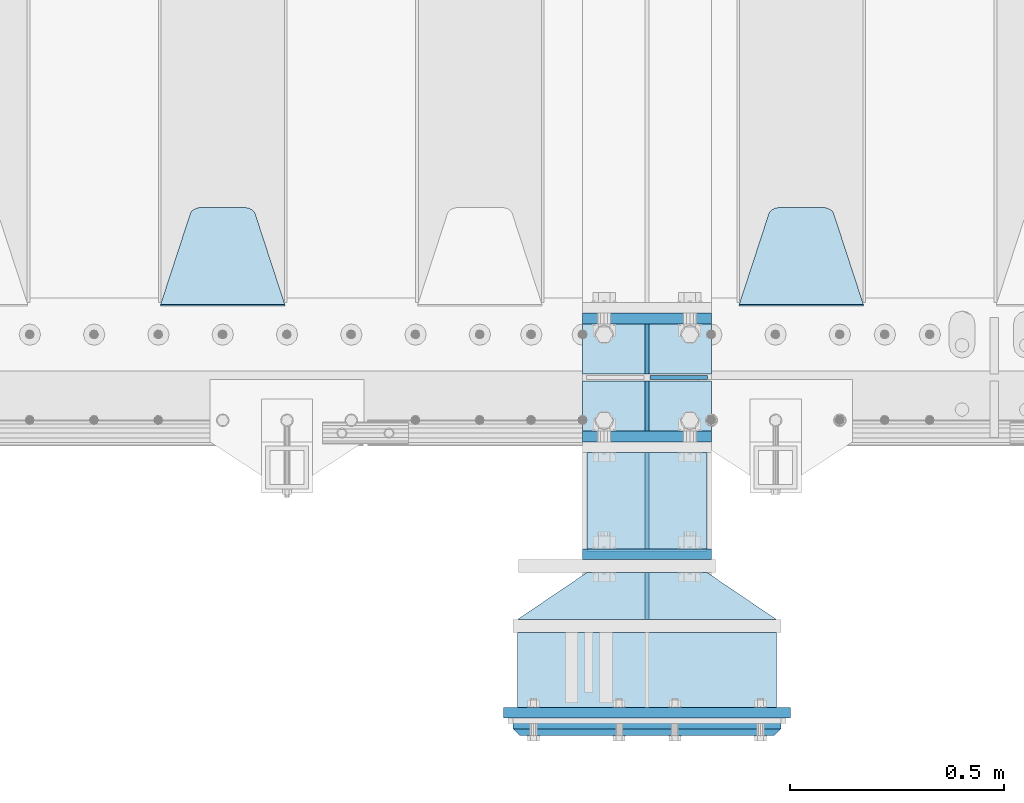
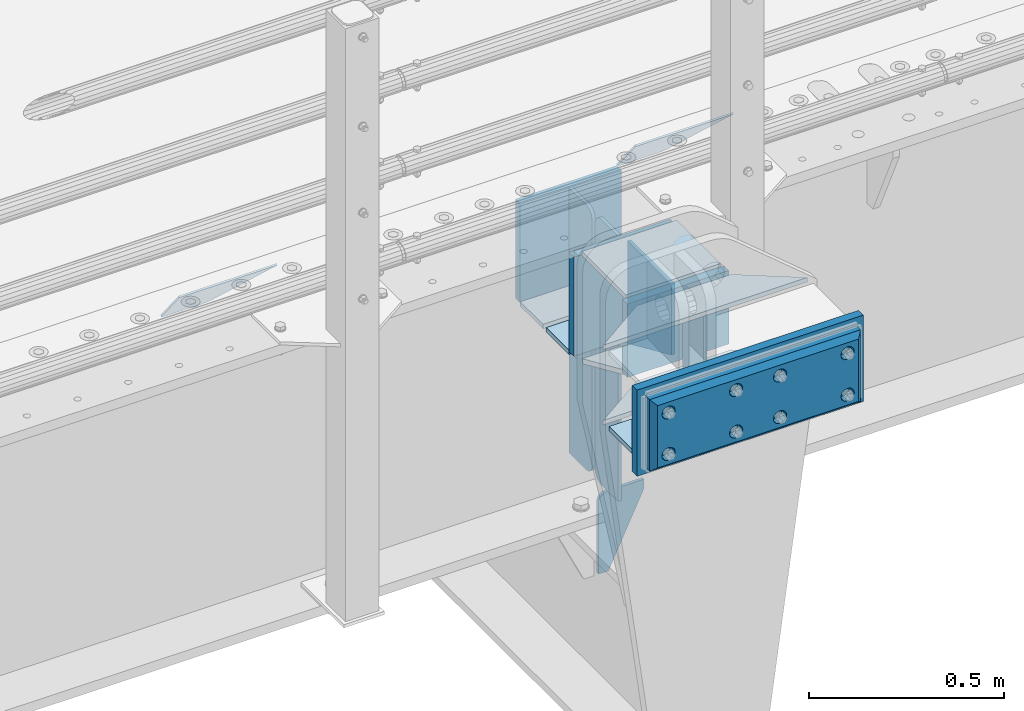
# One storey, part 166 of 193: 21 plates.
"""IFC2X3 building model written with IfcOpenShell, lengths in millimetres."""

from ifc_helpers import new_model, si_unit, frame, origin_with_axes, place, context, subcontext, project, spatial, faceted_brep, material, type_object, element, save


model = new_model("IFC2X3")

# Units and contexts
model_context = context("Model", 3, precision=1e-05, world=origin_with_axes())
body_context = subcontext(model_context, "Body", "Model", "MODEL_VIEW")
ifc_project = project(units=[si_unit("LENGTHUNIT", "METRE", prefix="MILLI"), si_unit("AREAUNIT", "SQUARE_METRE"), si_unit("VOLUMEUNIT", "CUBIC_METRE"), si_unit("MASSUNIT", "GRAM", prefix="KILO"), si_unit("TIMEUNIT", "SECOND"), si_unit("PLANEANGLEUNIT", "RADIAN"), si_unit("SOLIDANGLEUNIT", "STERADIAN"), si_unit("THERMODYNAMICTEMPERATUREUNIT", "DEGREE_CELSIUS"), si_unit("LUMINOUSINTENSITYUNIT", "LUMEN")], contexts=[model_context])

# Site, building, storey
site_placement = place(None, origin_with_axes())
site = spatial("IfcSite", under=ifc_project, at=site_placement, CompositionType="ELEMENT")
building_placement = place(site_placement, origin_with_axes())
building = spatial("IfcBuilding", under=site, at=building_placement, Name="Standard", CompositionType="ELEMENT")
storey_placement = place(building_placement, origin_with_axes())
storey = spatial("IfcBuildingStorey", under=building, at=storey_placement, Name="Undefined", CompositionType="ELEMENT", Elevation=0.0)

# Plates
ifc_material_1 = material(Name="STEEL/S355N")
plate_type_1 = type_object("IfcPlateType", PredefinedType="NOTDEFINED")
plate_1_placement = place(storey_placement, frame((-32199.9999999337, 23824.9999999954, -7.00001820618604), z_axis=(0.0, -1.0, 0.0), x_axis=(1.0, 0.0, 0.0)))
element("IfcPlate", 1, at=plate_1_placement, inside=storey, type_object=plate_type_1, material=ifc_material_1, context=body_context, shape_type="Brep", body=[
    faceted_brep([(0.0, -7.0, 0.0), (0.0, -7.0, 225.0), (0.0, 7.0, 225.0), (0.0, 7.0, 0.0), (280.0, -7.0, 225.0), (280.0, 7.0, 225.0), (280.0, -7.0, 0.0), (280.0, 7.0, 0.0)], [[[0, 1, 2, 3]], [[1, 4, 5, 2]], [[4, 6, 7, 5]], [[6, 0, 3, 7]], [[5, 7, 3, 2]], [[6, 4, 1, 0]]]),
])
plate_type_2 = type_object("IfcPlateType", PredefinedType="NOTDEFINED")
for number, where, z_axis, x_axis in (
    (2, (-32210.0, 23862.5, -340.0), (0.0, 0.0, 1.0), (1.0, 0.0, 0.0)),
    (3, (-32210.0, 24137.5, -340.0), (0.0, 0.0, 1.0), (1.0, 0.0, 0.0)),
):
    element("IfcPlate", number, at=place(storey_placement, frame(where, z_axis=z_axis, x_axis=x_axis)), inside=storey, type_object=plate_type_2, material=ifc_material_1, context=body_context, shape_type="Brep", body=[
        faceted_brep([(0.0, -12.5, 0.0), (0.0, -12.5, 310.0), (0.0, 12.5, 310.0), (0.0, 12.5, 0.0), (300.0, -12.5, 310.0), (300.0, 12.5, 310.0), (300.0, -12.5, 0.0), (300.0, 12.5, 0.0)], [[[0, 1, 2, 3]], [[1, 4, 5, 2]], [[4, 6, 7, 5]], [[6, 0, 3, 7]], [[5, 7, 3, 2]], [[6, 4, 1, 0]]]),
    ])
plate_type_3 = type_object("IfcPlateType", PredefinedType="NOTDEFINED")
for number, where, z_axis, x_axis in (
    (4, (-32210.0, 24008.0, -343.0), (0.0, 1.0, 0.0), (1.0, 0.0, 0.0)),
    (5, (-32210.0, 23992.0, -343.0), (0.0, -1.0, 0.0), (1.0, 0.0, 0.0)),
):
    element("IfcPlate", number, at=place(storey_placement, frame(where, z_axis=z_axis, x_axis=x_axis)), inside=storey, type_object=plate_type_3, material=ifc_material_1, context=body_context, shape_type="Brep", body=[
        faceted_brep([(0.0, -7.0, 0.0), (0.0, -7.0, 117.0), (0.0, 7.0, 117.0), (0.0, 7.0, 0.0), (300.0, -7.0, 117.0), (300.0, 7.0, 117.0), (300.0, -7.0, 0.0), (300.0, 7.0, 0.0)], [[[0, 1, 2, 3]], [[1, 4, 5, 2]], [[4, 6, 7, 5]], [[6, 0, 3, 7]], [[5, 7, 3, 2]], [[6, 4, 1, 0]]]),
    ])
plate_type_4 = type_object("IfcPlateType", PredefinedType="NOTDEFINED")
for number, where, z_axis, x_axis in (
    (6, (-32060.0, 23992.0, -30.0), (0.0, 0.0, -1.0), (0.0, -1.0, 0.0)),
    (7, (-32060.0, 24008.0, -30.0), (0.0, 0.0, -1.0), (0.0, 1.0, 0.0)),
):
    element("IfcPlate", number, at=place(storey_placement, frame(where, z_axis=z_axis, x_axis=x_axis)), inside=storey, type_object=plate_type_4, material=ifc_material_1, context=body_context, shape_type="Brep", body=[
        faceted_brep([(0.0, -5.0, 30.0), (0.0, -5.0, 306.0), (0.0, 5.0, 306.0), (0.0, 5.0, 30.0), (117.0, -5.0, 306.0), (117.0, 5.0, 306.0), (117.0, -5.0, 0.0), (117.0, 5.0, 0.0), (30.0, -5.0, 0.0), (30.0, 5.0, 0.0), (24.7905546699913, -5.0, 0.455767409633758), (24.7905546699913, 5.0, 0.455767409633758), (19.7393957002314, -5.0, 1.80922137642275), (19.7393957002314, 5.0, 1.80922137642275), (15.0, -5.0, 4.01923788646684), (15.0, 5.0, 4.01923788646684), (10.7163717094045, -5.0, 7.01866670643066), (10.7163717094045, 5.0, 7.01866670643066), (7.01866670642994, -5.0, 10.7163717094038), (7.01866670642994, 5.0, 10.7163717094038), (4.01923788646673, -5.0, 15.0), (4.01923788646673, 5.0, 15.0), (1.80922137642119, -5.0, 19.7393957002299), (1.80922137642119, 5.0, 19.7393957002299), (0.455767409632244, -5.0, 24.7905546699921), (0.455767409632244, 5.0, 24.7905546699921)], [[[0, 1, 2, 3]], [[1, 4, 5, 2]], [[4, 6, 7, 5]], [[6, 8, 9, 7]], [[8, 10, 11, 9]], [[10, 12, 13, 11]], [[12, 14, 15, 13]], [[14, 16, 17, 15]], [[16, 18, 19, 17]], [[18, 20, 21, 19]], [[20, 22, 23, 21]], [[22, 24, 25, 23]], [[24, 0, 3, 25]], [[5, 7, 9, 11, 13, 15, 17, 19, 21, 23, 25, 3, 2]], [[24, 22, 20, 18, 16, 14, 12, 10, 8, 6, 4, 1, 0]]]),
    ])
for number, where, z_axis, x_axis in (
    (8, (-32060.0, 23992.0, -350.0), (0.0, 0.0, -1.0), (0.0, -1.0, 0.0)),
    (9, (-32060.0, 24008.0, -350.0), (0.0, 0.0, -1.0), (0.0, 1.0, 0.0)),
):
    element("IfcPlate", number, at=place(storey_placement, frame(where, z_axis=z_axis, x_axis=x_axis)), inside=storey, type_object=plate_type_4, material=ifc_material_1, context=body_context, shape_type="Brep", body=[
        faceted_brep([(0.0, -5.0, 0.0), (0.0, -5.0, 480.0), (0.0, 5.0, 480.0), (0.0, 5.0, 0.0), (0.455767409632244, -5.0, 485.209445330008), (0.455767409632244, 5.0, 485.209445330008), (1.80922137642119, -5.0, 490.26060429977), (1.80922137642119, 5.0, 490.26060429977), (4.01923788646673, -5.0, 495.0), (4.01923788646673, 5.0, 495.0), (7.01866670642994, -5.0, 499.283628290596), (7.01866670642994, 5.0, 499.283628290596), (10.7163717094045, -5.0, 502.981333293569), (10.7163717094045, 5.0, 502.981333293569), (15.0, -5.0, 505.980762113533), (15.0, 5.0, 505.980762113533), (19.7393957002314, -5.0, 508.190778623577), (19.7393957002314, 5.0, 508.190778623577), (24.7905546699913, -5.0, 509.544232590366), (24.7905546699913, 5.0, 509.544232590366), (30.0, -5.0, 510.0), (30.0, 5.0, 510.0), (117.0, -5.0, 510.0), (117.0, 5.0, 510.0), (117.0, -5.0, 0.0), (117.0, 5.0, 0.0)], [[[0, 1, 2, 3]], [[1, 4, 5, 2]], [[4, 6, 7, 5]], [[6, 8, 9, 7]], [[8, 10, 11, 9]], [[10, 12, 13, 11]], [[12, 14, 15, 13]], [[14, 16, 17, 15]], [[16, 18, 19, 17]], [[18, 20, 21, 19]], [[20, 22, 23, 21]], [[22, 24, 25, 23]], [[24, 0, 3, 25]], [[5, 7, 9, 11, 13, 15, 17, 19, 21, 23, 25, 3, 2]], [[24, 22, 20, 18, 16, 14, 12, 10, 8, 6, 4, 1, 0]]]),
    ])
plate_type_5 = type_object("IfcPlateType", PredefinedType="NOTDEFINED")
plate_2_placement = place(storey_placement, frame((-32053.4999999333, 23999.9999999954, -915.000018206184), z_axis=(0.0, 0.0, -1.0), x_axis=(1.0, 0.0, 0.0)))
element("IfcPlate", 10, at=plate_2_placement, inside=storey, type_object=plate_type_5, material=ifc_material_1, context=body_context, shape_type="Brep", body=[
    faceted_brep([(0.0, -5.0, 27.0), (0.0, -5.0, 250.0), (0.0, 5.0, 250.0), (0.0, 5.0, 27.0), (30.0, -5.0, 250.0), (30.0, 5.0, 250.0), (135.0, -5.0, 30.0), (135.0, 5.0, 30.0), (135.0, -5.0, 0.0), (135.0, 5.0, 0.0), (27.0, -5.0, 0.0), (27.0, 5.0, 0.0), (22.3114992029914, -5.0, 0.410190668670339), (22.3114992029914, 5.0, 0.410190668670339), (17.7654561302079, -5.0, 1.62829923878041), (17.7654561302079, 5.0, 1.62829923878041), (13.5, -5.0, 3.61731409782021), (13.5, 5.0, 3.61731409782021), (9.64473453846222, -5.0, 6.31680003578765), (9.64473453846222, 5.0, 6.31680003578765), (6.31680003578731, -5.0, 9.64473453846347), (6.31680003578731, 5.0, 9.64473453846347), (3.61731409782078, -5.0, 13.5), (3.61731409782078, 5.0, 13.5), (1.62829923877871, -5.0, 17.765456130207), (1.62829923877871, 5.0, 17.765456130207), (0.410190668670111, -5.0, 22.3114992029929), (0.410190668670111, 5.0, 22.3114992029929)], [[[0, 1, 2, 3]], [[1, 4, 5, 2]], [[4, 6, 7, 5]], [[6, 8, 9, 7]], [[8, 10, 11, 9]], [[10, 12, 13, 11]], [[12, 14, 15, 13]], [[14, 16, 17, 15]], [[16, 18, 19, 17]], [[18, 20, 21, 19]], [[20, 22, 23, 21]], [[22, 24, 25, 23]], [[24, 26, 27, 25]], [[26, 0, 3, 27]], [[5, 7, 9, 11, 13, 15, 17, 19, 21, 23, 25, 27, 3, 2]], [[26, 24, 22, 20, 18, 16, 14, 12, 10, 8, 6, 4, 1, 0]]]),
])
plate_type_6 = type_object("IfcPlateType", PredefinedType="NOTDEFINED")
plate_3_placement = place(storey_placement, frame((-31555.0, 24168.232233047, -1.76776695296758), z_axis=(0.0, 0.707106781186547, -0.707106781186548), x_axis=(-1.0, 0.0, 0.0)))
element("IfcPlate", 11, at=plate_3_placement, inside=storey, type_object=plate_type_6, material=ifc_material_1, context=body_context, shape_type="Brep", body=[
    faceted_brep([(0.0, -2.5, 0.0), (69.345504679477, -2.50000000000364, 300.171731424831), (69.345504679477, 2.49999999999636, 300.171731424831), (0.0, 2.5, 0.0), (70.9274061199576, -2.50000000000364, 304.897442415397), (70.9274061199576, 2.49999999999636, 304.897442415397), (73.3818627772307, -2.50000000000364, 309.234538108529), (73.3818627772307, 2.49999999999636, 309.234538108529), (76.6187032999551, -2.50000000000728, 313.023683126103), (76.6187032999551, 2.49999999999636, 313.023683126103), (80.5190132704993, -2.50000000000364, 316.125672595372), (80.5190132704993, 2.49999999999636, 316.125672595368), (84.9395038596849, -2.50000000000364, 318.426546230472), (84.9395038596849, 2.49999999999636, 318.426546230476), (89.7177759439219, -2.50000000000364, 319.841774983273), (89.7177759439219, 2.49999999999636, 319.841774983277), (94.678286292652, -2.50000000000364, 320.319366455074), (94.678286292652, 2.49999999999636, 320.319366455074), (195.321713707348, -2.50000000000364, 320.319366455074), (195.321713707348, 2.49999999999636, 320.319366455074), (200.282224056078, -2.50000000000364, 319.841774983273), (200.282224056078, 2.49999999999636, 319.841774983277), (205.060496140315, -2.50000000000364, 318.426546230472), (205.060496140315, 2.49999999999636, 318.426546230472), (209.480986729501, -2.50000000000364, 316.125672595372), (209.480986729501, 2.49999999999636, 316.125672595368), (213.381296700045, -2.50000000000728, 313.023683126103), (213.381296700045, 2.49999999999272, 313.023683126103), (216.618137222769, -2.50000000000364, 309.234538108525), (216.618137222769, 2.49999999999636, 309.234538108522), (219.072593880042, -2.50000000000364, 304.897442415397), (219.072593880042, 2.49999999999636, 304.897442415397), (220.654495320523, -2.50000000000364, 300.171731424831), (220.654495320523, 2.49999999999636, 300.171731424831), (290.0, -2.50000000000364, 0.0), (290.0, 2.49999999999636, 0.0)], [[[0, 1, 2, 3]], [[1, 4, 5, 2]], [[4, 6, 7, 5]], [[6, 8, 9, 7]], [[8, 10, 11, 9]], [[10, 12, 13, 11]], [[12, 14, 15, 13]], [[14, 16, 17, 15]], [[16, 18, 19, 17]], [[18, 20, 21, 19]], [[20, 22, 23, 21]], [[22, 24, 25, 23]], [[24, 26, 27, 25]], [[26, 28, 29, 27]], [[28, 30, 31, 29]], [[30, 32, 33, 31]], [[32, 34, 35, 33]], [[34, 0, 3, 35]], [[5, 7, 9, 11, 13, 15, 17, 19, 21, 23, 25, 27, 29, 31, 33, 35, 3, 2]], [[34, 32, 30, 28, 26, 24, 22, 20, 18, 16, 14, 12, 10, 8, 6, 4, 1, 0]]]),
])
plate_4_placement = place(storey_placement, frame((-32905.0, 24168.232233047, -1.76776695296758), z_axis=(0.0, 0.707106781186547, -0.707106781186548), x_axis=(-1.0, 0.0, 0.0)))
element("IfcPlate", 12, at=plate_4_placement, inside=storey, type_object=plate_type_6, material=ifc_material_1, context=body_context, shape_type="Brep", body=[
    faceted_brep([(0.0, -2.5, 0.0), (69.345504679477, -2.50000000000364, 300.171731424831), (69.345504679477, 2.49999999999636, 300.171731424831), (0.0, 2.5, 0.0), (70.9274061199576, -2.50000000000364, 304.897442415397), (70.9274061199576, 2.49999999999636, 304.897442415397), (73.3818627772307, -2.50000000000364, 309.234538108529), (73.3818627772307, 2.49999999999636, 309.234538108529), (76.6187032999551, -2.50000000000728, 313.023683126103), (76.6187032999551, 2.49999999999636, 313.023683126103), (80.5190132704993, -2.50000000000364, 316.125672595372), (80.5190132704993, 2.49999999999636, 316.125672595368), (84.9395038596849, -2.50000000000364, 318.426546230472), (84.9395038596849, 2.49999999999636, 318.426546230476), (89.7177759439219, -2.50000000000364, 319.841774983273), (89.7177759439219, 2.49999999999636, 319.841774983277), (94.678286292652, -2.50000000000364, 320.319366455074), (94.678286292652, 2.49999999999636, 320.319366455074), (195.321713707348, -2.50000000000364, 320.319366455074), (195.321713707348, 2.49999999999636, 320.319366455074), (200.282224056078, -2.50000000000364, 319.841774983273), (200.282224056078, 2.49999999999636, 319.841774983277), (205.060496140315, -2.50000000000364, 318.426546230472), (205.060496140315, 2.49999999999636, 318.426546230472), (209.480986729501, -2.50000000000364, 316.125672595372), (209.480986729501, 2.49999999999636, 316.125672595368), (213.381296700045, -2.50000000000728, 313.023683126103), (213.381296700045, 2.49999999999272, 313.023683126103), (216.618137222769, -2.50000000000364, 309.234538108525), (216.618137222769, 2.49999999999636, 309.234538108522), (219.072593880042, -2.50000000000364, 304.897442415397), (219.072593880042, 2.49999999999636, 304.897442415397), (220.654495320523, -2.50000000000364, 300.171731424831), (220.654495320523, 2.49999999999636, 300.171731424831), (290.0, -2.50000000000364, 0.0), (290.0, 2.49999999999636, 0.0)], [[[0, 1, 2, 3]], [[1, 4, 5, 2]], [[4, 6, 7, 5]], [[6, 8, 9, 7]], [[8, 10, 11, 9]], [[10, 12, 13, 11]], [[12, 14, 15, 13]], [[14, 16, 17, 15]], [[16, 18, 19, 17]], [[18, 20, 21, 19]], [[20, 22, 23, 21]], [[22, 24, 25, 23]], [[24, 26, 27, 25]], [[26, 28, 29, 27]], [[28, 30, 31, 29]], [[30, 32, 33, 31]], [[32, 34, 35, 33]], [[34, 0, 3, 35]], [[5, 7, 9, 11, 13, 15, 17, 19, 21, 23, 25, 27, 29, 31, 33, 35, 3, 2]], [[34, 32, 30, 28, 26, 24, 22, 20, 18, 16, 14, 12, 10, 8, 6, 4, 1, 0]]]),
])
plate_type_7 = type_object("IfcPlateType", PredefinedType="NOTDEFINED")
plate_5_placement = place(storey_placement, frame((-32199.9999999337, 23822.1570307343, -342.396699047109), z_axis=(0.0, -0.913811548702731, 0.406138465867881), x_axis=(1.0, 0.0, 0.0)))
element("IfcPlate", 13, at=plate_5_placement, inside=storey, type_object=plate_type_7, material=ifc_material_1, context=body_context, shape_type="Brep", body=[
    faceted_brep([(0.0, -7.0, 0.0), (0.0, -7.0, 246.221450805664), (0.0, 6.99999999999818, 246.22145080566), (0.0, 7.0, 0.0), (280.0, -7.0, 246.221450805664), (280.0, 6.99999999999818, 246.22145080566), (280.0, -7.0, 0.0), (280.0, 7.0, 0.0)], [[[0, 1, 2, 3]], [[1, 4, 5, 2]], [[4, 6, 7, 5]], [[6, 0, 3, 7]], [[5, 7, 3, 2]], [[6, 4, 1, 0]]]),
])
ifc_material_2 = material()
plate_type_8 = type_object("IfcPlateType", PredefinedType="NOTDEFINED")
plate_6_placement = place(storey_placement, frame((-31757.4999999323, 23404.9999999953, -243.000018206186), z_axis=(0.0, -1.0, 0.0), x_axis=(-1.0, 0.0, 0.0)))
element("IfcPlate", 14, at=plate_6_placement, inside=storey, type_object=plate_type_8, material=ifc_material_2, context=body_context, shape_type="Brep", body=[
    faceted_brep([(0.0, -7.0, 0.0), (0.0, -7.0, 175.0), (0.0, 7.0, 175.0), (0.0, 7.0, 0.0), (605.0, -7.0, 175.0), (605.0, 7.0, 175.0), (605.0, -7.0, 0.0), (605.0, 7.0, 0.0)], [[[0, 1, 2, 3]], [[1, 4, 5, 2]], [[4, 6, 7, 5]], [[6, 0, 3, 7]], [[5, 7, 3, 2]], [[6, 4, 1, 0]]]),
])
plate_type_9 = type_object("IfcPlateType", PredefinedType="NOTDEFINED")
plate_7_placement = place(storey_placement, frame((-32059.9999999332, 23434.9999999954, -14.000018206186), z_axis=(0.0, 0.0, -1.0), x_axis=(0.0, 1.0, 0.0)))
element("IfcPlate", 15, at=plate_7_placement, inside=storey, type_object=plate_type_9, material=ifc_material_1, context=body_context, shape_type="Brep", body=[
    faceted_brep([(0.0, -5.0, 0.0), (0.0, -5.0, 222.0), (0.0, 5.0, 222.0), (0.0, 5.0, 0.0), (110.0, -5.0, 222.0), (110.0, 5.0, 222.0), (110.0, -5.0, 0.0), (110.0, 5.0, 0.0)], [[[0, 1, 2, 3]], [[1, 4, 5, 2]], [[4, 6, 7, 5]], [[6, 0, 3, 7]], [[5, 7, 3, 2]], [[6, 4, 1, 0]]]),
])
plate_type_10 = type_object("IfcPlateType", PredefinedType="NOTDEFINED")
for number, where, z_axis, x_axis in (
    (16, (-31757.4999999323, 23434.9999999953, -243.000018206186), (-0.560566412034006, -0.828109472050236, 0.0), (-0.828109472050235, 0.560566412034007, 0.0)),
    (17, (-31757.4999999323, 23434.9999999953, -7.00001820618604), (-0.560566412034006, -0.828109472050236, 0.0), (-0.828109472050235, 0.560566412034007, 0.0)),
):
    element("IfcPlate", number, at=place(storey_placement, frame(where, z_axis=z_axis, x_axis=x_axis)), inside=storey, type_object=plate_type_10, material=ifc_material_1, context=body_context, shape_type="Brep", body=[
        faceted_brep([(0.0, -7.0, 0.0), (501.00622558593, -7.0, 339.142669677742), (501.00622558593, 7.0, 339.142669677742), (0.0, 7.0, 0.0), (428.100738525383, -7.0, 156.958602905281), (428.100738525383, 7.0, 156.958602905281), (196.23008728027, -7.0, -3.63797880709171e-11), (196.23008728027, 7.0, -3.63797880709171e-11)], [[[0, 1, 2, 3]], [[1, 4, 5, 2]], [[4, 6, 7, 5]], [[6, 0, 3, 7]], [[5, 7, 3, 2]], [[6, 4, 1, 0]]]),
    ])
plate_type_11 = type_object("IfcPlateType", PredefinedType="NOTDEFINED")
plate_8_placement = place(storey_placement, frame((-32209.9999999336, 23587.4999999954, -240.000018206186), z_axis=(0.0, 0.0, 1.0), x_axis=(1.0, 0.0, 0.0)))
element("IfcPlate", 18, at=plate_8_placement, inside=storey, type_object=plate_type_11, material=ifc_material_1, context=body_context, shape_type="Brep", body=[
    faceted_brep([(0.0, -12.5, 0.0), (0.0, -12.5, 230.0), (0.0, 12.5, 230.0), (0.0, 12.5, 0.0), (300.0, -12.5, 230.0), (300.0, 12.5, 230.0), (300.0, -12.5, 0.0), (300.0, 12.5, 0.0)], [[[0, 1, 2, 3]], [[1, 4, 5, 2]], [[4, 6, 7, 5]], [[6, 0, 3, 7]], [[5, 7, 3, 2]], [[6, 4, 1, 0]]]),
])
ifc_material_3 = material()
plate_type_12 = type_object("IfcPlateType", PredefinedType="NOTDEFINED")
plate_9_placement = place(storey_placement, frame((-31747.4999999323, 23184.9999999952, -12.500018206186), z_axis=(0.0, 0.0, -1.0), x_axis=(-1.0, 0.0, 0.0)))
element("IfcPlate", 19, at=plate_9_placement, inside=storey, type_object=plate_type_12, material=ifc_material_3, context=body_context, shape_type="Brep", body=[
    faceted_brep([(0.0, -5.0, 0.0), (15.0, -20.0, 15.0), (15.0, -20.0, 210.0), (0.0, -5.0, 225.0), (625.0, -5.0, 225.0), (610.0, -20.0, 210.0), (610.0, -20.0, 15.0), (625.0, -5.0, 0.0), (625.0, 15.0, 0.0), (620.0, 20.0, 5.0), (620.0, 20.0, 220.0), (625.0, 15.0, 225.0), (0.0, 15.0, 225.0), (5.0, 20.0, 220.0), (5.0, 20.0, 5.0), (0.0, 15.0, 0.0), (30.179491924413, 5.00000000001455, 37.4999999999982), (37.5000000001019, 5.00000000001455, 30.1794919243094), (47.5000000001019, 5.00000000001455, 27.4999999999982), (57.5000000001019, 5.00000000001455, 30.1794919243094), (64.8205080757907, 5.00000000001455, 37.4999999999982), (67.5000000001019, 5.00000000001455, 47.4999999999982), (64.8205080757907, 5.00000000001455, 57.4999999999982), (57.5000000001019, 5.00000000001455, 64.8205080756869), (47.5000000001019, 5.00000000001455, 67.4999999999982), (37.5000000001019, 5.00000000001455, 64.820508075687), (30.179491924413, 5.00000000001455, 57.4999999999982), (27.5000000001019, 5.00000000001455, 47.4999999999982), (37.5000000001019, -20.0, 30.1794919243094), (30.179491924413, -20.0, 37.4999999999982), (47.5000000001019, -20.0, 27.4999999999982), (57.5000000001019, -20.0, 30.1794919243094), (64.8205080757907, -20.0, 37.4999999999982), (67.5000000001019, -20.0, 47.4999999999982), (64.8205080757907, -20.0, 57.4999999999982), (57.5000000001019, -20.0, 64.8205080756869), (47.5000000001019, -20.0, 67.4999999999982), (37.5000000001019, -20.0, 64.820508075687), (30.179491924413, -20.0, 57.4999999999982), (27.5000000001019, -20.0, 47.4999999999982), (230.179491924951, 5.0000000000764, 37.4999999999982), (237.50000000064, 5.0000000000764, 30.1794919243094), (247.50000000064, 5.0000000000764, 27.4999999999982), (257.50000000064, 5.0000000000764, 30.1794919243094), (264.820508076329, 5.0000000000764, 37.4999999999982), (267.50000000064, 5.0000000000764, 47.4999999999982), (264.820508076329, 5.0000000000764, 57.4999999999982), (257.50000000064, 5.0000000000764, 64.8205080756869), (247.50000000064, 5.0000000000764, 67.4999999999982), (237.50000000064, 5.0000000000764, 64.820508075687), (230.179491924951, 5.0000000000764, 57.4999999999982), (227.50000000064, 5.0000000000764, 47.4999999999982), (230.179491924951, -20.0, 37.4999999999982), (227.50000000064, -20.0, 47.4999999999982), (237.50000000064, -20.0, 30.1794919243094), (247.50000000064, -20.0, 27.4999999999982), (257.50000000064, -20.0, 30.1794919243094), (264.820508076329, -20.0, 37.4999999999982), (267.50000000064, -20.0, 47.4999999999982), (264.820508076329, -20.0, 57.4999999999982), (257.50000000064, -20.0, 64.8205080756869), (247.50000000064, -20.0, 67.4999999999982), (237.50000000064, -20.0, 64.820508075687), (230.179491924951, -20.0, 57.4999999999982), (560.179491925839, 5.0000000001819, 37.4999999999982), (567.500000001528, 5.0000000001819, 30.1794919243094), (577.500000001528, 5.0000000001819, 27.4999999999982), (587.500000001528, 5.0000000001819, 30.1794919243094), (594.820508077217, 5.0000000001819, 37.4999999999982), (597.500000001528, 5.0000000001819, 47.4999999999982), (594.820508077217, 5.0000000001819, 57.4999999999982), (587.500000001528, 5.0000000001819, 64.8205080756869), (577.500000001528, 5.0000000001819, 67.4999999999982), (567.500000001528, 5.0000000001819, 64.820508075687), (560.179491925839, 5.0000000001819, 57.4999999999982), (557.500000001528, 5.0000000001819, 47.4999999999982), (560.179491925839, -20.0, 37.4999999999982), (557.500000001528, -20.0, 47.4999999999982), (567.500000001528, -20.0, 30.1794919243094), (577.500000001528, -20.0, 27.4999999999982), (587.500000001528, -20.0, 30.1794919243094), (594.820508077217, -20.0, 37.4999999999982), (597.500000001528, -20.0, 47.4999999999982), (594.820508077217, -20.0, 57.4999999999982), (587.500000001528, -20.0, 64.8205080756869), (577.500000001528, -20.0, 67.4999999999982), (567.500000001528, -20.0, 64.820508075687), (560.179491925839, -20.0, 57.4999999999982), (560.179491925839, 5.0000000001819, 167.499999999998), (567.500000001528, 5.0000000001819, 160.179491924309), (577.500000001528, 5.0000000001819, 157.499999999998), (587.500000001528, 5.0000000001819, 160.179491924309), (594.820508077217, 5.0000000001819, 167.499999999998), (597.500000001528, 5.0000000001819, 177.499999999998), (594.820508077217, 5.0000000001819, 187.499999999998), (587.500000001528, 5.0000000001819, 194.820508075687), (577.500000001528, 5.0000000001819, 197.499999999998), (567.500000001528, 5.0000000001819, 194.820508075687), (560.179491925839, 5.0000000001819, 187.499999999998), (557.500000001528, 5.0000000001819, 177.499999999998), (560.179491925839, -20.0, 167.499999999998), (557.500000001528, -20.0, 177.499999999998), (567.500000001528, -20.0, 160.179491924309), (577.500000001528, -20.0, 157.499999999998), (587.500000001528, -20.0, 160.179491924309), (594.820508077217, -20.0, 167.499999999998), (597.500000001528, -20.0, 177.499999999998), (594.820508077217, -20.0, 187.499999999998), (587.500000001528, -20.0, 194.820508075687), (577.500000001528, -20.0, 197.499999999998), (567.500000001528, -20.0, 194.820508075687), (560.179491925839, -20.0, 187.499999999998), (230.179491924951, 5.0000000000764, 167.499999999998), (237.50000000064, 5.0000000000764, 160.179491924309), (247.50000000064, 5.0000000000764, 157.499999999998), (257.50000000064, 5.0000000000764, 160.179491924309), (264.820508076329, 5.0000000000764, 167.499999999998), (267.50000000064, 5.0000000000764, 177.499999999998), (264.820508076329, 5.0000000000764, 187.499999999998), (257.50000000064, 5.0000000000764, 194.820508075687), (247.50000000064, 5.0000000000764, 197.499999999998), (237.50000000064, 5.0000000000764, 194.820508075687), (230.179491924951, 5.0000000000764, 187.499999999998), (227.50000000064, 5.0000000000764, 177.499999999998), (230.179491924951, -20.0, 167.499999999998), (227.50000000064, -20.0, 177.499999999998), (237.50000000064, -20.0, 160.179491924309), (247.50000000064, -20.0, 157.499999999998), (257.50000000064, -20.0, 160.179491924309), (264.820508076329, -20.0, 167.499999999998), (267.50000000064, -20.0, 177.499999999998), (264.820508076329, -20.0, 187.499999999998), (257.50000000064, -20.0, 194.820508075687), (247.50000000064, -20.0, 197.499999999998), (237.50000000064, -20.0, 194.820508075687), (230.179491924951, -20.0, 187.499999999998), (30.179491924413, 5.00000000001455, 167.499999999998), (37.5000000001019, 5.00000000001455, 160.179491924309), (47.5000000001019, 5.00000000001455, 157.499999999998), (57.5000000001019, 5.00000000001455, 160.179491924309), (64.8205080757907, 5.00000000001455, 167.499999999998), (67.5000000001019, 5.00000000001455, 177.499999999998), (64.8205080757907, 5.00000000001455, 187.499999999998), (57.5000000001019, 5.00000000001455, 194.820508075687), (47.5000000001019, 5.00000000001455, 197.499999999998), (37.5000000001019, 5.00000000001455, 194.820508075687), (30.179491924413, 5.00000000001455, 187.499999999998), (27.5000000001019, 5.00000000001455, 177.499999999998), (30.179491924413, -20.0, 167.499999999998), (27.5000000001019, -20.0, 177.499999999998), (37.5000000001019, -20.0, 160.179491924309), (47.5000000001019, -20.0, 157.499999999998), (57.5000000001019, -20.0, 160.179491924309), (64.8205080757907, -20.0, 167.499999999998), (67.5000000001019, -20.0, 177.499999999998), (64.8205080757907, -20.0, 187.499999999998), (57.5000000001019, -20.0, 194.820508075687), (47.5000000001019, -20.0, 197.499999999998), (37.5000000001019, -20.0, 194.820508075687), (30.179491924413, -20.0, 187.499999999998), (360.179491925301, 5.00000000012005, 167.499999999998), (367.50000000099, 5.00000000012005, 160.179491924309), (377.50000000099, 5.00000000012005, 157.499999999998), (387.50000000099, 5.00000000012005, 160.179491924309), (394.820508076678, 5.00000000012005, 167.499999999998), (397.50000000099, 5.00000000012005, 177.499999999998), (394.820508076678, 5.00000000012005, 187.499999999998), (387.50000000099, 5.00000000012005, 194.820508075687), (377.50000000099, 5.00000000012005, 197.499999999998), (367.50000000099, 5.00000000012005, 194.820508075687), (360.179491925301, 5.00000000012005, 187.499999999998), (357.50000000099, 5.00000000012005, 177.499999999998), (360.179491925301, -20.0, 167.499999999998), (357.50000000099, -20.0, 177.499999999998), (367.50000000099, -20.0, 160.179491924309), (377.50000000099, -20.0, 157.499999999998), (387.50000000099, -20.0, 160.179491924309), (394.820508076678, -20.0, 167.499999999998), (397.50000000099, -20.0, 177.499999999998), (394.820508076678, -20.0, 187.499999999998), (387.50000000099, -20.0, 194.820508075687), (377.50000000099, -20.0, 197.499999999998), (367.50000000099, -20.0, 194.820508075687), (360.179491925301, -20.0, 187.499999999998), (360.179491925301, 5.00000000012005, 37.4999999999982), (367.50000000099, 5.00000000012005, 30.1794919243094), (377.50000000099, 5.00000000012005, 27.4999999999982), (387.50000000099, 5.00000000012005, 30.1794919243094), (394.820508076678, 5.00000000012005, 37.4999999999982), (397.50000000099, 5.00000000012005, 47.4999999999982), (394.820508076678, 5.00000000012005, 57.4999999999982), (387.50000000099, 5.00000000012005, 64.8205080756869), (377.50000000099, 5.00000000012005, 67.4999999999982), (367.50000000099, 5.00000000012005, 64.820508075687), (360.179491925301, 5.00000000012005, 57.4999999999982), (357.50000000099, 5.00000000012005, 47.4999999999982), (360.179491925301, -20.0, 37.4999999999982), (357.50000000099, -20.0, 47.4999999999982), (367.50000000099, -20.0, 30.1794919243094), (377.50000000099, -20.0, 27.4999999999982), (387.50000000099, -20.0, 30.1794919243094), (394.820508076678, -20.0, 37.4999999999982), (397.50000000099, -20.0, 47.4999999999982), (394.820508076678, -20.0, 57.4999999999982), (387.50000000099, -20.0, 64.8205080756869), (377.50000000099, -20.0, 67.4999999999982), (367.50000000099, -20.0, 64.820508075687), (360.179491925301, -20.0, 57.4999999999982)], [[[0, 1, 2, 3]], [[4, 5, 6, 7]], [[8, 9, 10, 11]], [[12, 13, 14, 15]], [[15, 14, 9, 8]], [[5, 4, 3, 2]], [[13, 12, 11, 10]], [[7, 6, 1, 0]], [[16, 17, 18, 19, 20, 21, 22, 23, 24, 25, 26, 27]], [[28, 17, 16, 29]], [[30, 18, 17, 28]], [[31, 19, 18, 30]], [[32, 20, 19, 31]], [[33, 21, 20, 32]], [[34, 22, 21, 33]], [[35, 23, 22, 34]], [[36, 24, 23, 35]], [[37, 25, 24, 36]], [[38, 26, 25, 37]], [[39, 27, 26, 38]], [[29, 16, 27, 39]], [[11, 12, 3, 4]], [[8, 11, 4, 7]], [[7, 0, 15, 8]], [[14, 13, 10, 9]], [[12, 15, 0, 3]], [[40, 41, 42, 43, 44, 45, 46, 47, 48, 49, 50, 51]], [[52, 40, 51, 53]], [[54, 41, 40, 52]], [[55, 42, 41, 54]], [[56, 43, 42, 55]], [[57, 44, 43, 56]], [[58, 45, 44, 57]], [[59, 46, 45, 58]], [[60, 47, 46, 59]], [[61, 48, 47, 60]], [[62, 49, 48, 61]], [[63, 50, 49, 62]], [[53, 51, 50, 63]], [[64, 65, 66, 67, 68, 69, 70, 71, 72, 73, 74, 75]], [[76, 64, 75, 77]], [[78, 65, 64, 76]], [[79, 66, 65, 78]], [[80, 67, 66, 79]], [[81, 68, 67, 80]], [[82, 69, 68, 81]], [[83, 70, 69, 82]], [[84, 71, 70, 83]], [[85, 72, 71, 84]], [[86, 73, 72, 85]], [[87, 74, 73, 86]], [[77, 75, 74, 87]], [[88, 89, 90, 91, 92, 93, 94, 95, 96, 97, 98, 99]], [[100, 88, 99, 101]], [[102, 89, 88, 100]], [[103, 90, 89, 102]], [[104, 91, 90, 103]], [[105, 92, 91, 104]], [[106, 93, 92, 105]], [[107, 94, 93, 106]], [[108, 95, 94, 107]], [[109, 96, 95, 108]], [[110, 97, 96, 109]], [[111, 98, 97, 110]], [[101, 99, 98, 111]], [[112, 113, 114, 115, 116, 117, 118, 119, 120, 121, 122, 123]], [[124, 112, 123, 125]], [[126, 113, 112, 124]], [[127, 114, 113, 126]], [[128, 115, 114, 127]], [[129, 116, 115, 128]], [[130, 117, 116, 129]], [[131, 118, 117, 130]], [[132, 119, 118, 131]], [[133, 120, 119, 132]], [[134, 121, 120, 133]], [[135, 122, 121, 134]], [[125, 123, 122, 135]], [[136, 137, 138, 139, 140, 141, 142, 143, 144, 145, 146, 147]], [[148, 136, 147, 149]], [[150, 137, 136, 148]], [[151, 138, 137, 150]], [[152, 139, 138, 151]], [[153, 140, 139, 152]], [[154, 141, 140, 153]], [[155, 142, 141, 154]], [[156, 143, 142, 155]], [[157, 144, 143, 156]], [[158, 145, 144, 157]], [[159, 146, 145, 158]], [[149, 147, 146, 159]], [[160, 161, 162, 163, 164, 165, 166, 167, 168, 169, 170, 171]], [[172, 160, 171, 173]], [[174, 161, 160, 172]], [[175, 162, 161, 174]], [[176, 163, 162, 175]], [[177, 164, 163, 176]], [[178, 165, 164, 177]], [[179, 166, 165, 178]], [[180, 167, 166, 179]], [[181, 168, 167, 180]], [[182, 169, 168, 181]], [[183, 170, 169, 182]], [[173, 171, 170, 183]], [[184, 185, 186, 187, 188, 189, 190, 191, 192, 193, 194, 195]], [[196, 184, 195, 197]], [[198, 185, 184, 196]], [[199, 186, 185, 198]], [[200, 187, 186, 199]], [[201, 188, 187, 200]], [[202, 189, 188, 201]], [[203, 190, 189, 202]], [[204, 191, 190, 203]], [[205, 192, 191, 204]], [[206, 193, 192, 205]], [[207, 194, 193, 206]], [[197, 195, 194, 207]], [[6, 5, 2, 1], [37, 36, 35, 34, 33, 32, 31, 30, 28, 29, 39, 38], [206, 205, 204, 203, 202, 201, 200, 199, 198, 196, 197, 207], [182, 181, 180, 179, 178, 177, 176, 175, 174, 172, 173, 183], [158, 157, 156, 155, 154, 153, 152, 151, 150, 148, 149, 159], [134, 133, 132, 131, 130, 129, 128, 127, 126, 124, 125, 135], [110, 109, 108, 107, 106, 105, 104, 103, 102, 100, 101, 111], [86, 85, 84, 83, 82, 81, 80, 79, 78, 76, 77, 87], [62, 61, 60, 59, 58, 57, 56, 55, 54, 52, 53, 63]]]),
])
plate_type_13 = type_object("IfcPlateType", PredefinedType="NOTDEFINED")
plate_10_placement = place(storey_placement, frame((-31724.9999999322, 23217.4999999952, 9.99998179381396), z_axis=(0.0, 0.0, -1.0), x_axis=(-1.0, 0.0, 0.0)))
element("IfcPlate", 20, at=plate_10_placement, inside=storey, type_object=plate_type_13, material=ifc_material_1, context=body_context, shape_type="Brep", body=[
    faceted_brep([(0.0, -12.5, 0.0), (0.0, -12.5, 270.0), (0.0, 12.5, 270.0), (0.0, 12.5, 0.0), (670.0, -12.5, 270.0), (670.0, 12.5, 270.0), (670.0, -12.5, 0.0), (670.0, 12.5, 0.0)], [[[0, 1, 2, 3]], [[1, 4, 5, 2]], [[4, 6, 7, 5]], [[6, 0, 3, 7]], [[5, 7, 3, 2]], [[6, 4, 1, 0]]]),
])
plate_type_14 = type_object("IfcPlateType", PredefinedType="NOTDEFINED")
plate_11_placement = place(storey_placement, frame((-32059.9999999333, 23824.9999999954, -336.000018206186), z_axis=(0.0, -1.0, 0.0), x_axis=(0.0, 0.0, 1.0)))
element("IfcPlate", 21, at=plate_11_placement, inside=storey, type_object=plate_type_14, material=ifc_material_1, context=body_context, shape_type="Brep", body=[
    faceted_brep([(0.0, -5.0, 0.0), (100.0, -5.0, 225.0), (100.0, 5.0, 225.0), (0.0, 5.0, 0.0), (322.0, -5.0, 225.0), (322.0, 5.0, 225.0), (322.0, -5.0, 0.0), (322.0, 5.0, 0.0)], [[[0, 1, 2, 3]], [[1, 4, 5, 2]], [[4, 6, 7, 5]], [[6, 0, 3, 7]], [[5, 7, 3, 2]], [[6, 4, 1, 0]]]),
])

save(model, "model.ifc")
